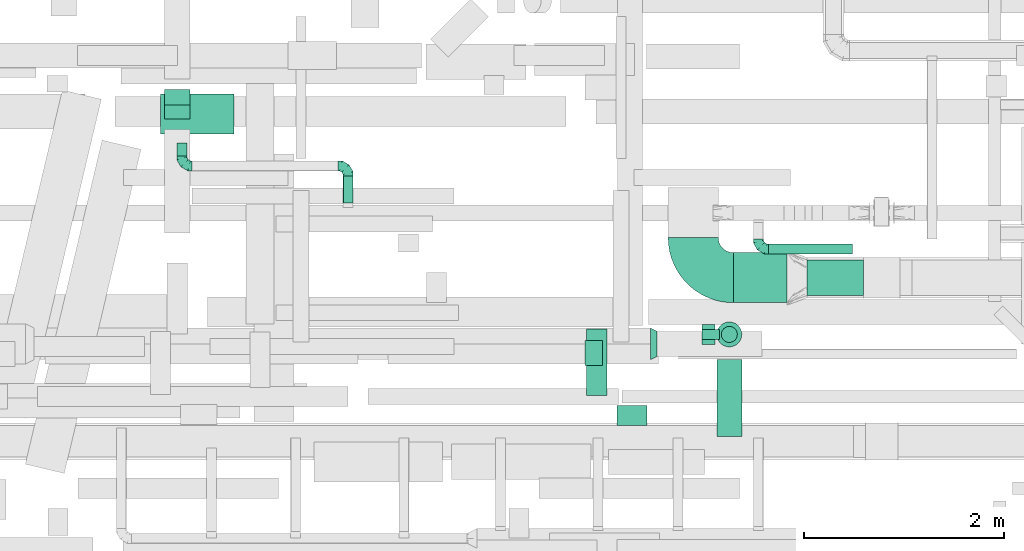
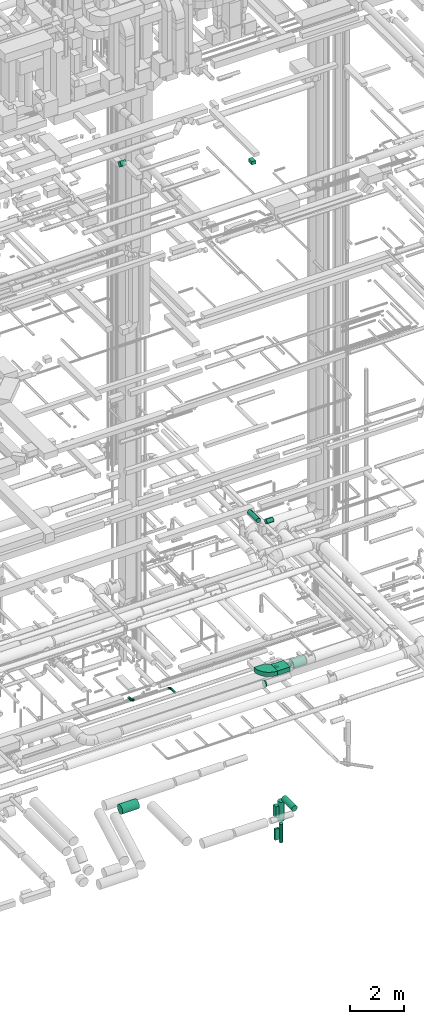
# One storey, part 207 of 337: 15 flow segments, 5 flow fittings.
"""IFC2X3 building model written with IfcOpenShell, lengths in millimetres."""

from ifc_helpers import new_model, entity, si_unit, converted_unit, derived_unit, direction, frame, frame_2d, origin, origin_2d_with_axis, place, context, subcontext, project, spatial, polyline, circle_curve, parameter, trimmed, segment, composite_curve, rectangle, circle, outline, extrude, faceted_brep, source, transform, mapped, material, type_object, type_shapes, element, save


model = new_model("IFC2X3")

# Units and contexts
model_context = context("Model", 3, precision=0.01, world=origin(), true_north=direction((6.12303176911189e-17, 1.0)))
body_context = subcontext(model_context, "Body", "Model", "MODEL_VIEW")
ifc_project = project(units=[si_unit("LENGTHUNIT", "METRE", prefix="MILLI"), si_unit("AREAUNIT", "SQUARE_METRE"), si_unit("VOLUMEUNIT", "CUBIC_METRE"), converted_unit("PLANEANGLEUNIT", "DEGREE", entity("IfcRatioMeasure", 0.0174532925199433), si_unit("PLANEANGLEUNIT", "RADIAN"), dimensions=[0, 0, 0, 0, 0, 0, 0]), si_unit("MASSUNIT", "GRAM", prefix="KILO"), derived_unit("MASSDENSITYUNIT", [(si_unit("MASSUNIT", "GRAM", prefix="KILO"), 1), (si_unit("LENGTHUNIT", "METRE"), -3)]), derived_unit("MOMENTOFINERTIAUNIT", [(si_unit("LENGTHUNIT", "METRE"), 4)]), si_unit("TIMEUNIT", "SECOND"), si_unit("FREQUENCYUNIT", "HERTZ"), si_unit("THERMODYNAMICTEMPERATUREUNIT", "DEGREE_CELSIUS"), derived_unit("THERMALTRANSMITTANCEUNIT", [(si_unit("MASSUNIT", "GRAM", prefix="KILO"), 1), (si_unit("THERMODYNAMICTEMPERATUREUNIT", "KELVIN"), -1), (si_unit("TIMEUNIT", "SECOND"), -3)]), derived_unit("VOLUMETRICFLOWRATEUNIT", [(si_unit("LENGTHUNIT", "METRE"), 3), (si_unit("TIMEUNIT", "SECOND"), -1)]), derived_unit("MASSFLOWRATEUNIT", [(si_unit("MASSUNIT", "GRAM", prefix="KILO"), 1), (si_unit("TIMEUNIT", "SECOND"), -1)]), derived_unit("ROTATIONALFREQUENCYUNIT", [(si_unit("TIMEUNIT", "SECOND"), -1)]), si_unit("ELECTRICCURRENTUNIT", "AMPERE"), si_unit("ELECTRICVOLTAGEUNIT", "VOLT"), si_unit("POWERUNIT", "WATT"), si_unit("FORCEUNIT", "NEWTON", prefix="KILO"), si_unit("ILLUMINANCEUNIT", "LUX"), si_unit("LUMINOUSFLUXUNIT", "LUMEN"), si_unit("LUMINOUSINTENSITYUNIT", "CANDELA"), derived_unit("USERDEFINED", [(si_unit("MASSUNIT", "GRAM", prefix="KILO"), -1), (si_unit("LENGTHUNIT", "METRE"), -2), (si_unit("TIMEUNIT", "SECOND"), 3), (si_unit("LUMINOUSFLUXUNIT", "LUMEN"), 1)]), derived_unit("LINEARVELOCITYUNIT", [(si_unit("LENGTHUNIT", "METRE"), 1), (si_unit("TIMEUNIT", "SECOND"), -1)]), si_unit("PRESSUREUNIT", "PASCAL"), derived_unit("USERDEFINED", [(si_unit("LENGTHUNIT", "METRE"), -2), (si_unit("MASSUNIT", "GRAM", prefix="KILO"), 1), (si_unit("TIMEUNIT", "SECOND"), -2)]), derived_unit("LINEARFORCEUNIT", [(si_unit("MASSUNIT", "GRAM", prefix="KILO"), 1), (si_unit("LENGTHUNIT", "METRE"), 1), (si_unit("TIMEUNIT", "SECOND"), -2), (si_unit("LENGTHUNIT", "METRE"), -1)]), derived_unit("PLANARFORCEUNIT", [(si_unit("MASSUNIT", "GRAM", prefix="KILO"), 1), (si_unit("LENGTHUNIT", "METRE"), 1), (si_unit("TIMEUNIT", "SECOND"), -2), (si_unit("LENGTHUNIT", "METRE"), -2)])], contexts=[model_context])

# Site, building, storey
site_placement = place(None, origin())
site = spatial("IfcSite", under=ifc_project, at=site_placement, CompositionType="ELEMENT")
building_placement = place(site_placement, origin())
building = spatial("IfcBuilding", under=site, at=building_placement, CompositionType="ELEMENT")
storey_placement = place(building_placement, origin())
storey = spatial("IfcBuildingStorey", under=building, at=storey_placement, CompositionType="ELEMENT", Elevation=0.0)

# Flow segments
duct_segment_type_1 = type_object("IfcDuctSegmentType", PredefinedType="NOTDEFINED")
flow_segment_1_placement = place(storey_placement, frame((60414.13, 2797.54, -2850.0)))
element("IfcFlowSegment", 1, at=flow_segment_1_placement, inside=storey, type_object=duct_segment_type_1, context=body_context, shape_type="SweptSolid", body=[
    extrude(rectangle(XDim=129.999999999996, YDim=200.0, at=origin_2d_with_axis()), frame((65.0, 100.0, 0.0), z_axis=(0.0, 0.0, 1.0), x_axis=(-1.0, 0.0, 0.0)), (0.0, 0.0, 1.0), 500.0),
])
flow_segment_2_placement = place(storey_placement, frame((60414.13, 2847.54, -3900.0)))
element("IfcFlowSegment", 2, at=flow_segment_2_placement, inside=storey, type_object=duct_segment_type_1, context=body_context, shape_type="SweptSolid", body=[
    extrude(rectangle(XDim=174.999999999995, YDim=100.0, at=origin_2d_with_axis()), frame((87.5, 50.0, 0.0), z_axis=(0.0, 0.0, 1.0), x_axis=(-1.0, 0.0, 0.0)), (0.0, 0.0, 1.0), 500.0),
])
flow_segment_3_placement = place(storey_placement, frame((59249.3, 2587.91, 27475.0)))
element("IfcFlowSegment", 3, at=flow_segment_3_placement, inside=storey, type_object=duct_segment_type_1, context=body_context, shape_type="SweptSolid", body=[
    extrude(rectangle(XDim=175.269119345844, YDim=250.0, at=origin_2d_with_axis()), frame((87.63, 125.0, 0.0), z_axis=(0.0, 0.0, 1.0), x_axis=(-1.0, 0.0, 0.0)), (0.0, 0.0, 1.0), 150.000000000001),
])
flow_segment_4_placement = place(storey_placement, frame((55054.59, 5047.37, 27252.51)))
element("IfcFlowSegment", 4, at=flow_segment_4_placement, inside=storey, type_object=duct_segment_type_1, context=body_context, shape_type="SweptSolid", body=[
    extrude(rectangle(XDim=217.157287525368, YDim=199.999999999997, at=origin_2d_with_axis()), frame((0.0, 147.49, 147.49), z_axis=(1.0, 0.0, 0.0), x_axis=(0.0, 0.707106781186498, -0.707106781186597)), (0.0, 0.0, 1.0), 250.000000000004),
])
flow_segment_5_placement = place(storey_placement, frame((60728.78, 3214.15, 3300.0)))
element("IfcFlowSegment", 5, at=flow_segment_5_placement, inside=storey, type_object=duct_segment_type_1, context=body_context, shape_type="SweptSolid", body=[
    extrude(rectangle(XDim=534.447448798547, YDim=500.0, at=origin_2d_with_axis()), frame((267.22, 250.0, 0.0), z_axis=(0.0, 0.0, 1.0), x_axis=(-1.0, 0.0, 0.0)), (0.0, 0.0, 1.0), 200.0),
])
duct_segment_type_2 = type_object("IfcDuctSegmentType", PredefinedType="NOTDEFINED")
flow_segment_6_placement = place(storey_placement, frame((55013.15, 4896.73, -2151.6)))
element("IfcFlowSegment", 6, at=flow_segment_6_placement, inside=storey, type_object=duct_segment_type_2, context=body_context, shape_type="SweptSolid", body=[
    extrude(circle(Radius=200.0, at=origin_2d_with_axis()), frame((0.0, 201.6, 201.6), z_axis=(1.0, 0.0, 0.0), x_axis=(0.0, -1.0, 0.0)), (0.0, 0.0, 1.0), 730.830177170377),
])
flow_segment_7_placement = place(storey_placement, frame((60562.54, 1876.52, -2076.6)))
element("IfcFlowSegment", 7, at=flow_segment_7_placement, inside=storey, type_object=duct_segment_type_2, context=body_context, shape_type="SweptSolid", body=[
    extrude(circle(Radius=125.0, at=origin_2d_with_axis()), frame((126.6, 0.0, 126.6), z_axis=(0.0, 1.0, 0.0), x_axis=(1.0, 0.0, 0.0)), (0.0, 0.0, 1.0), 771.024518339497),
])
flow_segment_8_placement = place(storey_placement, frame((60607.54, 2815.95, -4077.64)))
element("IfcFlowSegment", 8, at=flow_segment_8_placement, inside=storey, type_object=duct_segment_type_2, context=body_context, shape_type="SweptSolid", body=[
    extrude(circle(Radius=80.0, at=origin_2d_with_axis()), frame((81.6, 81.6, 0.0)), (0.0, 0.0, 1.0), 839.999998963608),
])
flow_segment_9_placement = place(storey_placement, frame((60562.54, 2770.95, -3083.64)))
element("IfcFlowSegment", 9, at=flow_segment_9_placement, inside=storey, type_object=duct_segment_type_2, context=body_context, shape_type="SweptSolid", body=[
    extrude(outline(polyline([(-16.32, -123.93), (16.32, -123.93), (47.84, -115.48), (76.1, -99.17), (99.17, -76.1), (115.48, -47.84), (123.93, -16.32), (123.93, 16.32), (115.48, 47.84), (99.17, 76.1), (76.1, 99.17), (47.84, 115.48), (16.32, 123.93), (-16.32, 123.93), (-47.84, 115.48), (-76.1, 99.17), (-99.17, 76.1), (-115.48, 47.84), (-123.93, 16.32), (-123.93, -16.32), (-115.48, -47.84), (-99.17, -76.1), (-76.1, -99.17), (-47.84, -115.48), (-16.32, -123.93)])), frame((126.6, 126.6, 0.0), z_axis=(0.0, -1.75950579788378e-09, 1.0), x_axis=(-0.130526192220055, 0.99144486137381, 1.74445169309743e-09)), (0.0, 0.0, 1.0), 883.639712944482),
])
flow_segment_10_placement = place(storey_placement, frame((59566.15, 1986.28, 11298.4)))
element("IfcFlowSegment", 10, at=flow_segment_10_placement, inside=storey, type_object=duct_segment_type_2, context=body_context, shape_type="SweptSolid", body=[
    extrude(circle(Radius=100.0, at=origin_2d_with_axis()), frame((0.0, 101.6, 101.6), z_axis=(1.0, 0.0, 0.0), x_axis=(0.0, -1.0, 0.0)), (0.0, 0.0, 1.0), 299.999999999958),
])
flow_segment_11_placement = place(storey_placement, frame((59264.56, 2287.88, 11298.4)))
element("IfcFlowSegment", 11, at=flow_segment_11_placement, inside=storey, type_object=duct_segment_type_2, context=body_context, shape_type="SweptSolid", body=[
    extrude(circle(Radius=100.0, at=origin_2d_with_axis()), frame((101.6, 0.0, 101.6), z_axis=(0.0, 1.0, 0.0), x_axis=(-1.0, 0.0, 0.0)), (0.0, 0.0, 1.0), 664.99999999974),
])
flow_segment_12_placement = place(storey_placement, frame((61463.23, 3285.06, 3220.9)))
element("IfcFlowSegment", 12, at=flow_segment_12_placement, inside=storey, type_object=duct_segment_type_2, context=body_context, shape_type="SweptSolid", body=[
    extrude(circle(Radius=177.5, at=origin_2d_with_axis()), frame((0.0, 179.1, 179.1), z_axis=(1.0, 0.0, 0.0), x_axis=(0.0, -1.0, 0.0)), (0.0, 0.0, 1.0), 564.269860199671),
])
flow_segment_13_placement = place(storey_placement, frame((56833.47, 4210.29, 3198.4)))
element("IfcFlowSegment", 13, at=flow_segment_13_placement, inside=storey, type_object=duct_segment_type_2, context=body_context, shape_type="SweptSolid", body=[
    extrude(circle(Radius=50.0, at=origin_2d_with_axis()), frame((51.6, 0.0, 51.6), z_axis=(0.0, 1.0, 0.0), x_axis=(-1.0, 0.0, 0.0)), (0.0, 0.0, 1.0), 270.000000000006),
])
flow_segment_14_placement = place(storey_placement, frame((55173.47, 4680.29, 3198.4)))
element("IfcFlowSegment", 14, at=flow_segment_14_placement, inside=storey, type_object=duct_segment_type_2, context=body_context, shape_type="SweptSolid", body=[
    extrude(circle(Radius=50.0, at=origin_2d_with_axis()), frame((51.6, 0.0, 51.6), z_axis=(0.0, 1.0, 0.0), x_axis=(1.0, 0.0, 0.0)), (0.0, 0.0, 1.0), 129.999999999999),
])
flow_segment_15_placement = place(storey_placement, frame((61078.74, 3698.69, 3198.4)))
element("IfcFlowSegment", 15, at=flow_segment_15_placement, inside=storey, type_object=duct_segment_type_2, context=body_context, shape_type="SweptSolid", body=[
    extrude(circle(Radius=50.0, at=origin_2d_with_axis()), frame((0.0, 51.6, 51.6), z_axis=(1.0, 0.0, 0.0), x_axis=(0.0, -1.0, 0.0)), (0.0, 0.0, 1.0), 840.000000000008),
])

# Flow fittings
ifc_material = material()
duct_fitting_type_1 = type_object("IfcDuctFittingType", PredefinedType="NOTDEFINED", material=ifc_material)
shared_shape_1 = source(origin(), body_context, "Body", "Brep", [
    faceted_brep([(-100.0, 0.0, -50.0), (-100.0, -12.94, -48.3), (-100.0, -25.0, -43.3), (-100.0, -35.36, -35.36), (-100.0, -43.3, -25.0), (-100.0, -48.3, -12.94), (-100.0, -50.0, 0.0), (-100.0, -48.3, 12.94), (-100.0, -43.3, 25.0), (-100.0, -35.36, 35.36), (-100.0, -25.0, 43.3), (-100.0, -12.94, 48.3), (-100.0, 0.0, 50.0), (-100.0, 12.94, 48.3), (-100.0, 25.0, 43.3), (-100.0, 35.36, 35.36), (-100.0, 43.3, 25.0), (-100.0, 48.3, 12.94), (-100.0, 50.0, 0.0), (-100.0, 48.3, -12.94), (-100.0, 43.3, -25.0), (-100.0, 35.36, -35.36), (-100.0, 25.0, -43.3), (-100.0, 12.94, -48.3), (-76.67, 12.94, 48.3), (-79.9, 25.0, 43.3), (-73.21, 0.0, 50.0), (-82.68, 35.36, 35.36), (-86.15, 48.3, 12.94), (-86.6, 50.0, 0.0), (-84.81, 43.3, 25.0), (-84.81, 43.3, -25.0), (-82.68, 35.36, -35.36), (-86.15, 48.3, -12.94), (-76.67, 12.94, -48.3), (-73.21, 0.0, -50.0), (-79.9, 25.0, -43.3), (-69.74, -12.94, -48.3), (-66.51, -25.0, -43.3), (-63.73, -35.36, -35.36), (-61.6, -43.3, -25.0), (-60.26, -48.3, -12.94), (-59.81, -50.0, 0.0), (-60.26, -48.3, 12.94), (-61.6, -43.3, 25.0), (-63.73, -35.36, 35.36), (-66.51, -25.0, 43.3), (-69.74, -12.94, 48.3), (-36.27, 36.27, 48.3), (-45.1, 45.1, 43.3), (-26.79, 26.79, 50.0), (-52.68, 52.68, 35.36), (-58.49, 58.49, 25.0), (-62.15, 62.15, 12.94), (-63.4, 63.4, 0.0), (-62.15, 62.15, -12.94), (-58.49, 58.49, -25.0), (-52.68, 52.68, -35.36), (-36.27, 36.27, -48.3), (-26.79, 26.79, -50.0), (-45.1, 45.1, -43.3), (-17.32, 17.32, -48.3), (-8.49, 8.49, -43.3), (-0.91, 0.91, -35.36), (4.9, -4.9, -25.0), (8.56, -8.56, -12.94), (9.81, -9.81, 0.0), (8.56, -8.56, 12.94), (4.9, -4.9, 25.0), (-0.91, 0.91, 35.36), (-8.49, 8.49, 43.3), (-17.32, 17.32, 48.3), (-12.94, 76.67, 48.3), (-25.0, 79.9, 43.3), (0.0, 73.21, 50.0), (-35.36, 82.68, 35.36), (-43.3, 84.81, 25.0), (-48.3, 86.15, 12.94), (-50.0, 86.6, 0.0), (-48.3, 86.15, -12.94), (-43.3, 84.81, -25.0), (-35.36, 82.68, -35.36), (-12.94, 76.67, -48.3), (0.0, 73.21, -50.0), (-25.0, 79.9, -43.3), (12.94, 69.74, -48.3), (25.0, 66.51, -43.3), (35.36, 63.73, -35.36), (43.3, 61.6, -25.0), (48.3, 60.26, -12.94), (50.0, 59.81, 0.0), (48.3, 60.26, 12.94), (43.3, 61.6, 25.0), (35.36, 63.73, 35.36), (25.0, 66.51, 43.3), (12.94, 69.74, 48.3), (-12.94, 100.0, -48.3), (-25.0, 100.0, -43.3), (-35.36, 100.0, -35.36), (-43.3, 100.0, -25.0), (-48.3, 100.0, -12.94), (-50.0, 100.0, 0.0), (-48.3, 100.0, 12.94), (-43.3, 100.0, 25.0), (-35.36, 100.0, 35.36), (-25.0, 100.0, 43.3), (-12.94, 100.0, 48.3), (0.0, 100.0, 50.0), (12.94, 100.0, 48.3), (25.0, 100.0, 43.3), (35.36, 100.0, 35.36), (43.3, 100.0, 25.0), (48.3, 100.0, 12.94), (50.0, 100.0, 0.0), (48.3, 100.0, -12.94), (43.3, 100.0, -25.0), (35.36, 100.0, -35.36), (25.0, 100.0, -43.3), (12.94, 100.0, -48.3), (0.0, 100.0, -50.0)], [[[0, 1, 2, 3, 4, 5, 6, 7, 8, 9, 10, 11, 12, 13, 14, 15, 16, 17, 18, 19, 20, 21, 22, 23]], [[24, 25, 14, 13]], [[26, 24, 13, 12]], [[14, 25, 27, 15]], [[28, 29, 18, 17]], [[30, 28, 17, 16]], [[15, 27, 30, 16]], [[20, 31, 32, 21]], [[33, 31, 20, 19]], [[18, 29, 33, 19]], [[34, 35, 0, 23]], [[36, 34, 23, 22]], [[32, 36, 22, 21]], [[2, 1, 37, 38]], [[3, 2, 38, 39]], [[0, 35, 37, 1]], [[5, 4, 40, 41]], [[6, 5, 41, 42]], [[3, 39, 40, 4]], [[6, 42, 43, 7]], [[7, 43, 44, 8]], [[8, 44, 45, 9]], [[10, 46, 47, 11]], [[11, 47, 26, 12]], [[10, 9, 45, 46]], [[48, 49, 25, 24]], [[50, 48, 24, 26]], [[27, 25, 49, 51]], [[52, 53, 28, 30]], [[51, 52, 30, 27]], [[29, 28, 53, 54]], [[55, 56, 31, 33]], [[54, 55, 33, 29]], [[57, 32, 31, 56]], [[58, 59, 35, 34]], [[60, 58, 34, 36]], [[57, 60, 36, 32]], [[37, 35, 59, 61]], [[38, 37, 61, 62]], [[39, 38, 62, 63]], [[41, 40, 64, 65]], [[42, 41, 65, 66]], [[63, 64, 40, 39]], [[43, 42, 66, 67]], [[44, 43, 67, 68]], [[68, 69, 45, 44]], [[46, 45, 69, 70]], [[47, 46, 70, 71]], [[26, 47, 71, 50]], [[72, 73, 49, 48]], [[74, 72, 48, 50]], [[51, 49, 73, 75]], [[76, 77, 53, 52]], [[75, 76, 52, 51]], [[54, 53, 77, 78]], [[79, 80, 56, 55]], [[78, 79, 55, 54]], [[81, 57, 56, 80]], [[82, 83, 59, 58]], [[84, 82, 58, 60]], [[81, 84, 60, 57]], [[61, 59, 83, 85]], [[62, 61, 85, 86]], [[63, 62, 86, 87]], [[65, 64, 88, 89]], [[66, 65, 89, 90]], [[87, 88, 64, 63]], [[67, 66, 90, 91]], [[68, 67, 91, 92]], [[92, 93, 69, 68]], [[70, 69, 93, 94]], [[71, 70, 94, 95]], [[50, 71, 95, 74]], [[96, 97, 98, 99, 100, 101, 102, 103, 104, 105, 106, 107, 108, 109, 110, 111, 112, 113, 114, 115, 116, 117, 118, 119]], [[72, 74, 107, 106]], [[73, 72, 106, 105]], [[75, 73, 105, 104]], [[77, 76, 103, 102]], [[78, 77, 102, 101]], [[75, 104, 103, 76]], [[78, 101, 100, 79]], [[79, 100, 99, 80]], [[80, 99, 98, 81]], [[96, 119, 83, 82]], [[97, 96, 82, 84]], [[84, 81, 98, 97]], [[83, 119, 118, 85]], [[85, 118, 117, 86]], [[86, 117, 116, 87]], [[88, 115, 114, 89]], [[89, 114, 113, 90]], [[87, 116, 115, 88]], [[91, 90, 113, 112]], [[92, 91, 112, 111]], [[93, 92, 111, 110]], [[95, 94, 109, 108]], [[74, 95, 108, 107]], [[110, 109, 94, 93]]]),
])
type_shapes(duct_fitting_type_1, [shared_shape_1])
for number, where, z_axis, x_axis in (
    (16, (55225.06, 4580.29, 3250.0), (0.0, 0.0, 1.0), (0.0, -1.0, 0.0)),
    (17, (60978.74, 3750.29, 3250.0), (0.0, 0.0, 1.0), (0.0, -1.0, 0.0)),
    (18, (56885.06, 4580.29, 3250.0), (0.0, 0.0, 1.0), (0.0, 1.0, 0.0)),
):
    element("IfcFlowFitting", number, at=place(storey_placement, frame(where, z_axis=z_axis, x_axis=x_axis)), inside=storey, type_object=duct_fitting_type_1, material=ifc_material, context=body_context, shape_type="MappedRepresentation", body=[
        mapped(shared_shape_1, transform((0.0, 0.0, 0.0), scale=1.0)),
    ])
duct_fitting_type_2 = type_object("IfcDuctFittingType", PredefinedType="NOTDEFINED", material=ifc_material)
shared_shape_2 = source(origin(), body_context, "Body", "Brep", [
    faceted_brep([(65.0, 101.13, -73.47), (65.0, 118.88, -38.63), (65.0, 125.0, 0.0), (65.0, 118.88, 38.63), (65.0, 101.13, 73.47), (65.0, 73.47, 101.13), (65.0, 38.63, 118.88), (65.0, 0.0, 125.0), (65.0, -38.63, 118.88), (65.0, -73.47, 101.13), (65.0, -101.13, 73.47), (65.0, -118.88, 38.63), (65.0, -125.0, 0.0), (65.0, -118.88, -38.63), (65.0, -101.13, -73.47), (65.0, -73.47, -101.13), (65.0, -38.63, -118.88), (65.0, 0.0, -125.0), (65.0, 38.63, -118.88), (65.0, 73.47, -101.13), (0.0, -157.5, 0.0), (0.0, -152.13, 40.76), (0.0, -136.4, 78.75), (0.0, -111.37, 111.37), (0.0, -78.75, 136.4), (0.0, -40.76, 152.13), (0.0, 0.0, 157.5), (0.0, 40.76, 152.13), (0.0, 78.75, 136.4), (0.0, 111.37, 111.37), (0.0, 136.4, 78.75), (0.0, 152.13, 40.76), (0.0, 157.5, 0.0), (0.0, 152.13, -40.76), (0.0, 136.4, -78.75), (0.0, 111.37, -111.37), (0.0, 78.75, -136.4), (0.0, 40.76, -152.13), (0.0, 0.0, -157.5), (0.0, -40.76, -152.13), (0.0, -78.75, -136.4), (0.0, -111.37, -111.37), (0.0, -136.4, -78.75), (0.0, -152.13, -40.76)], [[[0, 1, 2, 3, 4, 5, 6, 7, 8, 9, 10, 11, 12, 13, 14, 15, 16, 17, 18, 19]], [[20, 21, 22, 23, 24, 25, 26, 27, 28, 29, 30, 31, 32, 33, 34, 35, 36, 37, 38, 39, 40, 41, 42, 43]], [[6, 5, 28]], [[7, 6, 27]], [[7, 27, 26]], [[27, 6, 28]], [[5, 29, 28]], [[3, 2, 31]], [[4, 3, 30]], [[30, 29, 4]], [[31, 30, 3]], [[2, 32, 31]], [[4, 29, 5]], [[11, 10, 22]], [[12, 11, 21]], [[12, 21, 20]], [[21, 11, 22]], [[10, 23, 22]], [[8, 7, 25]], [[9, 8, 24]], [[24, 23, 9]], [[25, 24, 8]], [[7, 26, 25]], [[9, 23, 10]], [[16, 15, 40]], [[17, 16, 39]], [[17, 39, 38]], [[39, 16, 40]], [[15, 41, 40]], [[13, 12, 43]], [[14, 13, 42]], [[42, 41, 14]], [[43, 42, 13]], [[12, 20, 43]], [[14, 41, 15]], [[1, 0, 34]], [[2, 1, 33]], [[2, 33, 32]], [[33, 1, 34]], [[0, 35, 34]], [[18, 17, 37]], [[19, 18, 36]], [[36, 35, 19]], [[37, 36, 18]], [[17, 38, 37]], [[19, 35, 0]]]),
])
type_shapes(duct_fitting_type_2, [shared_shape_2])
flow_fitting_1_placement = place(storey_placement, frame((59903.23, 2803.74, 3450.0)))
element("IfcFlowFitting", 19, at=flow_fitting_1_placement, inside=storey, type_object=duct_fitting_type_2, material=ifc_material, context=body_context, shape_type="MappedRepresentation", body=[
    mapped(shared_shape_2, transform((0.0, 0.0, 0.0), scale=1.0)),
])
duct_fitting_type_3 = type_object("IfcDuctFittingType", PredefinedType="NOTDEFINED", material=ifc_material)
shared_shape_3 = source(origin(), body_context, "Body", "SweptSolid", [
    extrude(outline(composite_curve([segment(polyline([(-450.0, -200.0), (50.0, -200.0)]), True, "CONTINUOUS"), segment(trimmed(circle_curve(frame_2d((200.0, -200.0), x_axis=(0.0, 1.0)), 150.0), [parameter(0.0)], [parameter(90.0000000000001)], True, "PARAMETER"), False, "CONTINUOUS"), segment(polyline([(200.0, -50.0), (200.0, 450.0)]), True, "CONTINUOUS"), segment(trimmed(circle_curve(frame_2d((200.0, -200.0), x_axis=(0.0, 1.0)), 650.0), [parameter(0.0)], [parameter(90.0000000000001)], True, "PARAMETER"), True, "CONTINUOUS")], self_intersect=False)), frame((-200.0, 200.0, -100.0), z_axis=(0.0, 0.0, 1.0), x_axis=(-1.0, 0.0, 0.0)), (0.0, 0.0, 1.0), 200.0),
])
type_shapes(duct_fitting_type_3, [shared_shape_3])
flow_fitting_2_placement = place(storey_placement, frame((60328.78, 3464.15, 3400.0), z_axis=(0.0, 0.0, 1.0), x_axis=(0.0, -1.0, 0.0)))
element("IfcFlowFitting", 20, at=flow_fitting_2_placement, inside=storey, type_object=duct_fitting_type_3, material=ifc_material, context=body_context, shape_type="MappedRepresentation", body=[
    mapped(shared_shape_3, transform((0.0, 0.0, 0.0), scale=1.0)),
])

save(model, "model.ifc")
